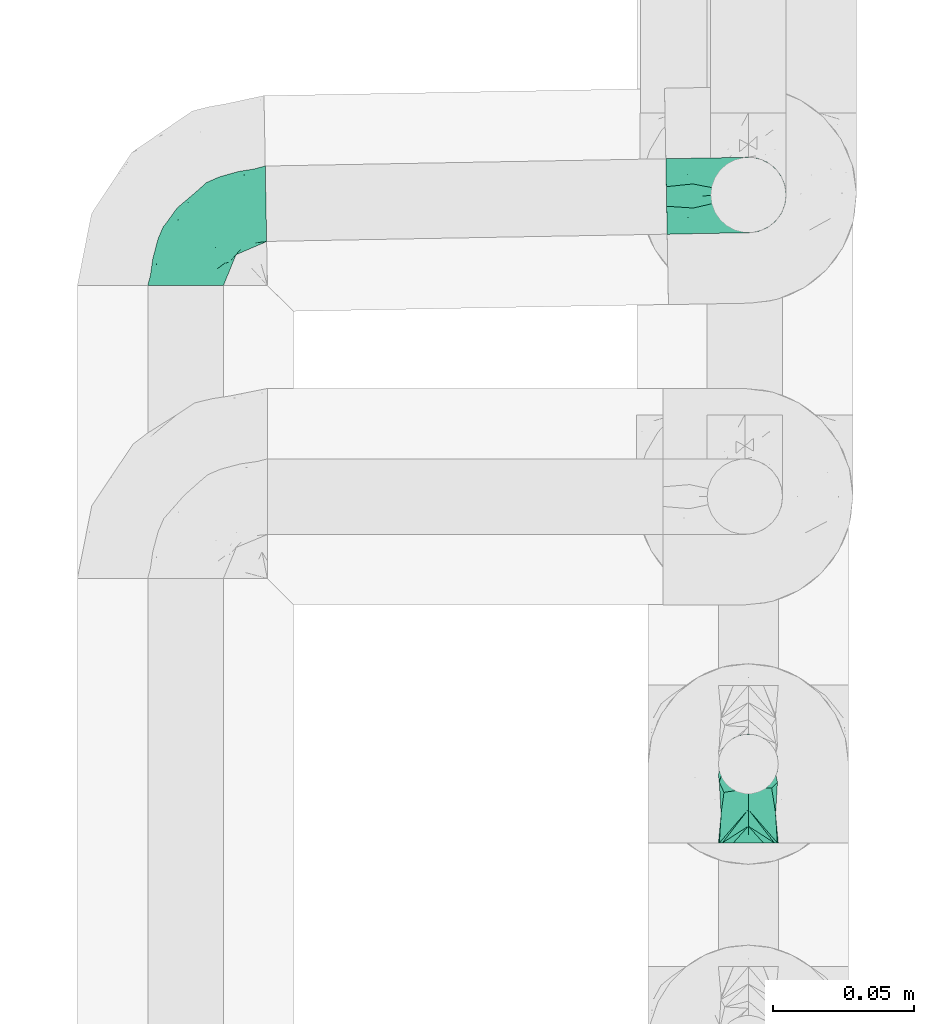
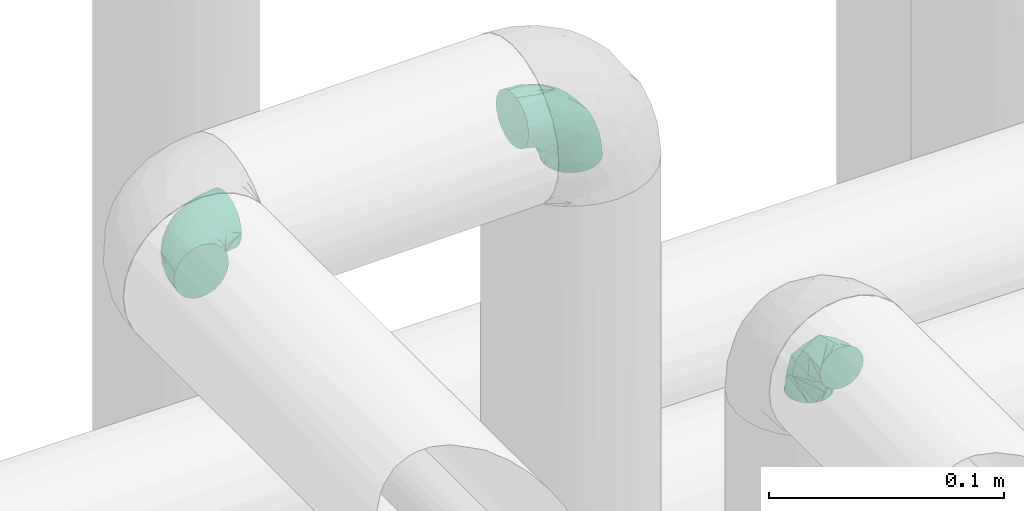
# One storey, part 813 of 827: 3 flow fittings.
"""IFC2X3 building model written with IfcOpenShell, lengths in millimetres."""

import ifcopenshell
import ifcopenshell.guid

model = None  # the IFC model being written
_history = None  # IfcOwnerHistory: only IFC2X3 demands one
_inside = {}  # id of a spatial element -> (the spatial element, [elements in it])
_under = {}  # id of a project, library or spatial element -> (it, [spatial elements below it])
_declared = {}  # id of a project -> (the project, [libraries it declares])
_typed = {}  # id of a type object -> (the type object, [elements of that type])
_made_of = {}  # id of a material, layer set ... -> (it, [elements and type objects made of it])


def new_model(schema):
    """Start an empty IFC model of exactly this schema.

    Asked for "IFC4X3", IfcOpenShell would pick the latest addendum, in which some entities
    have other attributes; the version numbers below select the first issue.
    IFC2X3 requires an IfcOwnerHistory on every rooted entity: one is made here for all.
    """
    global model, _history
    if schema == "IFC4X3":
        model = ifcopenshell.file(schema_version=(4, 3, 0, 0))
    else:
        model = ifcopenshell.file(schema=schema)
    _inside.clear()
    _under.clear()
    _declared.clear()
    _typed.clear()
    _made_of.clear()
    _history = None
    if model.schema == "IFC2X3":
        org = make("IfcOrganization", Name="unknown")
        user = make(
            "IfcPersonAndOrganization",
            ThePerson=make("IfcPerson", FamilyName="unknown"),
            TheOrganization=org,
        )
        app = make(
            "IfcApplication",
            ApplicationDeveloper=org,
            Version="unknown",
            ApplicationFullName="unknown",
            ApplicationIdentifier="unknown",
        )
        _history = make(
            "IfcOwnerHistory",
            OwningUser=user,
            OwningApplication=app,
            ChangeAction="ADDED",
            CreationDate=0,
        )
    return model


def make(cls, **values):
    """One entity of the class cls with the attributes given. An attribute that is None is left unset."""
    return model.create_entity(
        cls, **{name: value for name, value in values.items() if value is not None}
    )


def entity(cls, *values):
    """Any entity or typed value of the class cls, its attributes in the order of the schema. None: left unset."""
    e = model.create_entity(cls)
    for i, value in enumerate(values):
        if value is not None:
            e[i] = value
    return e


def rooted(cls, **values):
    """An entity with a GlobalId (a new one), such as an element, a storey or a relation."""
    return make(cls, GlobalId=ifcopenshell.guid.new(), OwnerHistory=_history, **values)


def si_unit(unit_type, name, prefix=None):
    """IfcSIUnit, for example si_unit("LENGTHUNIT", "METRE", prefix="MILLI")."""
    return make("IfcSIUnit", UnitType=unit_type, Prefix=prefix, Name=name)


def converted_unit(unit_type, name, factor, base, dimensions=None, offset=None):
    """IfcConversionBasedUnit, such as the inch: factor (a typed value) times the base unit."""
    return make(
        "IfcConversionBasedUnit"
        if offset is None
        else "IfcConversionBasedUnitWithOffset",
        ConversionOffset=offset,
        Dimensions=None
        if dimensions is None
        else entity("IfcDimensionalExponents", *dimensions),
        UnitType=unit_type,
        Name=name,
        ConversionFactor=make(
            "IfcMeasureWithUnit", ValueComponent=factor, UnitComponent=base
        ),
    )


def derived_unit(unit_type, elements):
    """IfcDerivedUnit: a product of units, each with its exponent."""
    return make(
        "IfcDerivedUnit",
        Elements=[
            make("IfcDerivedUnitElement", Unit=unit, Exponent=power)
            for unit, power in elements
        ],
        UnitType=unit_type,
    )


def assignment(units):
    """IfcUnitAssignment: the units of a project."""
    return None if units is None else make("IfcUnitAssignment", Units=units)


def point(xyz):
    """IfcCartesianPoint."""
    return None if xyz is None else make("IfcCartesianPoint", Coordinates=xyz)


def direction(xyz):
    """IfcDirection."""
    return None if xyz is None else make("IfcDirection", DirectionRatios=xyz)


def frame(location, z_axis=None, x_axis=None):
    """IfcAxis2Placement3D, a coordinate frame: its origin and axes. An axis left out is left unset."""
    return make(
        "IfcAxis2Placement3D",
        Location=point(location),
        Axis=direction(z_axis),
        RefDirection=direction(x_axis),
    )


def origin():
    """The frame at (0, 0, 0) with its axes left unset."""
    return frame((0.0, 0.0, 0.0))


def place(relative_to, where):
    """IfcLocalPlacement: puts the frame where relative to a parent placement (None: the world)."""
    return make(
        "IfcLocalPlacement", PlacementRelTo=relative_to, RelativePlacement=where
    )


def context(
    kind, dimensions, precision=None, world=None, true_north=None, identifier=None
):
    """IfcGeometricRepresentationContext, for example the 3D "Model" context."""
    return make(
        "IfcGeometricRepresentationContext",
        ContextIdentifier=identifier,
        ContextType=kind,
        CoordinateSpaceDimension=dimensions,
        Precision=precision,
        WorldCoordinateSystem=world,
        TrueNorth=true_north,
    )


def subcontext(parent, identifier, kind, view, scale=None):
    """IfcGeometricRepresentationSubContext, for example "Body" below "Model"."""
    return make(
        "IfcGeometricRepresentationSubContext",
        ContextIdentifier=identifier,
        ContextType=kind,
        ParentContext=parent,
        TargetScale=scale,
        TargetView=view,
    )


def project(units=None, contexts=None):
    """IfcProject with its units and contexts."""
    return rooted(
        "IfcProject",
        Name="project",
        RepresentationContexts=contexts,
        UnitsInContext=assignment(units),
    )


def spatial(cls, under=None, at=None, **own):
    """A site, building, storey or space (cls), placed at a placement, below another one or the project."""
    s = rooted(cls, ObjectPlacement=at, **own)
    if under is not None:
        _under.setdefault(under.id(), (under, []))[1].append(s)
    return s


def faces_of(points, faces, orient=None, outer=None):
    """IfcFace entities. A face is a list of loops; a loop is a list of indices into points, from 0.

    orient and outer hold one flag for each loop. By default every Orientation is true, the
    first loop of a face is its IfcFaceOuterBound and the others are IfcFaceBound.
    """
    made = []
    for i, loops in enumerate(faces):
        bounds = []
        for j, loop in enumerate(loops):
            is_outer = j == 0 if outer is None else outer[i][j]
            bounds.append(
                make(
                    "IfcFaceOuterBound" if is_outer else "IfcFaceBound",
                    Bound=make("IfcPolyLoop", Polygon=[points[k] for k in loop]),
                    Orientation=True if orient is None else orient[i][j],
                )
            )
        made.append(make("IfcFace", Bounds=bounds))
    return made


def faceted_brep(points, faces, orient=None, outer=None, voids=None):
    """IfcFacetedBrep: a solid bounded by flat faces; with voids (closed shells), ...WithVoids."""
    shared = [point(p) for p in points]
    hull = make("IfcClosedShell", CfsFaces=faces_of(shared, faces, orient, outer))
    if voids is None:
        return make("IfcFacetedBrep", Outer=hull)
    return make(
        "IfcFacetedBrepWithVoids",
        Outer=hull,
        Voids=[
            make(cls, CfsFaces=faces_of(shared, fs, o, b)) for cls, fs, o, b in voids
        ],
    )


def shape(context_of_items, identifier, shape_type, items):
    """IfcShapeRepresentation: the items that make up one representation, for example the "Body"."""
    return make(
        "IfcShapeRepresentation",
        ContextOfItems=context_of_items,
        RepresentationIdentifier=identifier,
        RepresentationType=shape_type,
        Items=items,
    )


def source(mapping_origin, context_of_items, identifier, shape_type, items):
    """IfcRepresentationMap: a shape defined once, which mapped items show again and again."""
    return make(
        "IfcRepresentationMap",
        MappingOrigin=mapping_origin,
        MappedRepresentation=shape(context_of_items, identifier, shape_type, items),
    )


def transform(
    local_origin,
    x_axis=None,
    y_axis=None,
    z_axis=None,
    scale=None,
    scale2=None,
    scale3=None,
    uniform=True,
):
    """IfcCartesianTransformationOperator3D, or its non-uniform kind. x_axis, y_axis, z_axis: its Axis1, 2, 3."""
    if uniform:
        return make(
            "IfcCartesianTransformationOperator3D",
            Axis1=direction(x_axis),
            Axis2=direction(y_axis),
            LocalOrigin=point(local_origin),
            Scale=scale,
            Axis3=direction(z_axis),
        )
    return make(
        "IfcCartesianTransformationOperator3DnonUniform",
        Axis1=direction(x_axis),
        Axis2=direction(y_axis),
        LocalOrigin=point(local_origin),
        Scale=scale,
        Axis3=direction(z_axis),
        Scale2=scale2,
        Scale3=scale3,
    )


def mapped(mapping_source, mapping_target):
    """IfcMappedItem: shows the shape of a source again, moved by a transform."""
    return make(
        "IfcMappedItem", MappingSource=mapping_source, MappingTarget=mapping_target
    )


def material(Name=None, Category=None):
    """IfcMaterial."""
    return make("IfcMaterial", Name=Name, Category=Category)


def made_of(thing, what):
    """Note that an element or type object is made of a material, layer set ...; save() writes the relation."""
    if what is not None:
        _made_of.setdefault(what.id(), (what, []))[1].append(thing)
    return thing


def type_object(cls, material=None, **own):
    """A type object (cls), such as IfcWallType, which elements share."""
    return made_of(rooted(cls, **own), material)


def type_shapes(of_type, sources):
    """Give a type object the sources (RepresentationMaps) that its elements show as mapped items."""
    of_type.RepresentationMaps = sources


def element(
    cls,
    number,
    at=None,
    inside=None,
    cuts=None,
    type_object=None,
    material=None,
    context=None,
    identifier="Body",
    shape_type=None,
    held_by="IfcProductDefinitionShape",
    body=None,
    shapes=None,
    **own,
):
    """One element of the class cls, such as IfcWall. Its Tag is "e" and its number.

    at: its placement. inside: the storey or other place that contains it. cuts: it is an
    opening in that element (IfcRelVoidsElement). A single representation is given by context,
    identifier, shape_type and body (its items); several are given by shapes. held_by: the class
    of the entity that holds the representations. save() writes the other relations.
    """
    e = rooted(cls, Tag="e%d" % number, ObjectPlacement=at, **own)
    if body is not None:
        shapes = [shape(context, identifier, shape_type, body)]
    if shapes is not None:
        e.Representation = make(held_by, Representations=shapes)
    if inside is not None:
        _inside.setdefault(inside.id(), (inside, []))[1].append(e)
    if cuts is not None:
        rooted(
            "IfcRelVoidsElement", RelatingBuildingElement=cuts, RelatedOpeningElement=e
        )
    if type_object is not None:
        _typed.setdefault(type_object.id(), (type_object, []))[1].append(e)
    return made_of(e, material)


def aggregate(whole, parts):
    """IfcRelAggregates: a whole, such as a stair, and the parts it consists of."""
    return rooted("IfcRelAggregates", RelatingObject=whole, RelatedObjects=parts)


def save(model, path):
    """Write the relations noted so far, then the file.

    IfcRelAggregates (storeys below a building ...), IfcRelContainedInSpatialStructure (elements
    in a storey), IfcRelDefinesByType, IfcRelAssociatesMaterial and IfcRelDeclares: one each for
    every whole, place, type object, material and project.
    """
    for whole, parts in _under.values():
        aggregate(whole, parts)
    for where, things in _inside.values():
        rooted(
            "IfcRelContainedInSpatialStructure",
            RelatedElements=things,
            RelatingStructure=where,
        )
    for kind, things in _typed.values():
        rooted("IfcRelDefinesByType", RelatedObjects=things, RelatingType=kind)
    for what, things in _made_of.values():
        rooted("IfcRelAssociatesMaterial", RelatedObjects=things, RelatingMaterial=what)
    for by, libraries in _declared.values():
        rooted("IfcRelDeclares", RelatingContext=by, RelatedDefinitions=libraries)
    model.write(path)


model = new_model("IFC2X3")

# Units and contexts
model_context = context("Model", 3, precision=0.01, world=origin(), true_north=direction((6.12303176911189e-17, 1.0)))
body_context = subcontext(model_context, "Body", "Model", "MODEL_VIEW")
ifc_project = project(units=[si_unit("LENGTHUNIT", "METRE", prefix="MILLI"), si_unit("AREAUNIT", "SQUARE_METRE"), si_unit("VOLUMEUNIT", "CUBIC_METRE"), converted_unit("PLANEANGLEUNIT", "DEGREE", entity("IfcRatioMeasure", 0.0174532925199433), si_unit("PLANEANGLEUNIT", "RADIAN"), dimensions=[0, 0, 0, 0, 0, 0, 0]), si_unit("MASSUNIT", "GRAM", prefix="KILO"), derived_unit("MASSDENSITYUNIT", [(si_unit("MASSUNIT", "GRAM", prefix="KILO"), 1), (si_unit("LENGTHUNIT", "METRE"), -3)]), derived_unit("MOMENTOFINERTIAUNIT", [(si_unit("LENGTHUNIT", "METRE"), 4)]), si_unit("TIMEUNIT", "SECOND"), si_unit("FREQUENCYUNIT", "HERTZ"), si_unit("THERMODYNAMICTEMPERATUREUNIT", "DEGREE_CELSIUS"), derived_unit("THERMALTRANSMITTANCEUNIT", [(si_unit("MASSUNIT", "GRAM", prefix="KILO"), 1), (si_unit("THERMODYNAMICTEMPERATUREUNIT", "KELVIN"), -1), (si_unit("TIMEUNIT", "SECOND"), -3)]), derived_unit("VOLUMETRICFLOWRATEUNIT", [(si_unit("LENGTHUNIT", "METRE"), 3), (si_unit("TIMEUNIT", "SECOND"), -1)]), derived_unit("MASSFLOWRATEUNIT", [(si_unit("MASSUNIT", "GRAM", prefix="KILO"), 1), (si_unit("TIMEUNIT", "SECOND"), -1)]), derived_unit("ROTATIONALFREQUENCYUNIT", [(si_unit("TIMEUNIT", "SECOND"), -1)]), si_unit("ELECTRICCURRENTUNIT", "AMPERE"), si_unit("ELECTRICVOLTAGEUNIT", "VOLT"), si_unit("POWERUNIT", "WATT"), si_unit("FORCEUNIT", "NEWTON", prefix="KILO"), si_unit("ILLUMINANCEUNIT", "LUX"), si_unit("LUMINOUSFLUXUNIT", "LUMEN"), si_unit("LUMINOUSINTENSITYUNIT", "CANDELA"), derived_unit("USERDEFINED", [(si_unit("MASSUNIT", "GRAM", prefix="KILO"), -1), (si_unit("LENGTHUNIT", "METRE"), -2), (si_unit("TIMEUNIT", "SECOND"), 3), (si_unit("LUMINOUSFLUXUNIT", "LUMEN"), 1)]), derived_unit("LINEARVELOCITYUNIT", [(si_unit("LENGTHUNIT", "METRE"), 1), (si_unit("TIMEUNIT", "SECOND"), -1)]), si_unit("PRESSUREUNIT", "PASCAL"), derived_unit("USERDEFINED", [(si_unit("LENGTHUNIT", "METRE"), -2), (si_unit("MASSUNIT", "GRAM", prefix="KILO"), 1), (si_unit("TIMEUNIT", "SECOND"), -2)]), derived_unit("LINEARFORCEUNIT", [(si_unit("MASSUNIT", "GRAM", prefix="KILO"), 1), (si_unit("LENGTHUNIT", "METRE"), 1), (si_unit("TIMEUNIT", "SECOND"), -2), (si_unit("LENGTHUNIT", "METRE"), -1)]), derived_unit("PLANARFORCEUNIT", [(si_unit("MASSUNIT", "GRAM", prefix="KILO"), 1), (si_unit("LENGTHUNIT", "METRE"), 1), (si_unit("TIMEUNIT", "SECOND"), -2), (si_unit("LENGTHUNIT", "METRE"), -2)])], contexts=[model_context])

# Site, building, storey
site_placement = place(None, origin())
site = spatial("IfcSite", under=ifc_project, at=site_placement, CompositionType="ELEMENT")
building_placement = place(site_placement, origin())
building = spatial("IfcBuilding", under=site, at=building_placement, CompositionType="ELEMENT")
storey_placement = place(building_placement, frame((0.0, 0.0, 28200.0)))
storey = spatial("IfcBuildingStorey", under=building, at=storey_placement, Name="08", CompositionType="ELEMENT", Elevation=28200.0)

# Flow fittings
ifc_material = material()
pipe_fitting_type_1 = type_object("IfcPipeFittingType", Name="ADSK_1", PredefinedType="NOTDEFINED", material=ifc_material)
shared_shape_1 = source(origin(), body_context, "Body", "Brep", [
    faceted_brep([(-28.0, 2.76, -10.29), (-28.0, 0.0, -10.65), (-28.0, -2.76, -10.29), (-28.0, -5.33, -9.22), (-28.0, -7.53, -7.53), (-28.0, -9.22, -5.33), (-28.0, -10.29, -2.76), (-28.0, -10.65, 0.0), (-28.0, -10.29, 2.76), (-28.0, -9.22, 5.32), (-28.0, -7.53, 7.53), (-28.0, -5.33, 9.22), (-28.0, -2.76, 10.29), (-28.0, 0.0, 10.65), (-28.0, 2.76, 10.29), (-28.0, 5.32, 9.22), (-28.0, 7.53, 7.53), (-28.0, 9.22, 5.32), (-28.0, 10.29, 2.76), (-28.0, 10.65, 0.0), (-28.0, 10.29, -2.76), (-28.0, 9.22, -5.33), (-28.0, 7.53, -7.53), (-28.0, 5.32, -9.22), (0.0, 28.0, -10.65), (-2.76, 28.0, -10.29), (-5.33, 28.0, -9.22), (-7.53, 28.0, -7.53), (-9.23, 28.0, -5.33), (-10.29, 28.0, -2.76), (-10.65, 28.0, 0.0), (-10.29, 28.0, 2.76), (-9.23, 28.0, 5.32), (-7.53, 28.0, 7.53), (-5.33, 28.0, 9.22), (-2.76, 28.0, 10.29), (0.0, 28.0, 10.65), (2.75, 28.0, 10.29), (5.32, 28.0, 9.22), (7.53, 28.0, 7.53), (9.22, 28.0, 5.32), (10.28, 28.0, 2.76), (10.65, 28.0, 0.0), (10.28, 28.0, -2.76), (9.22, 28.0, -5.33), (7.53, 28.0, -7.53), (5.32, 28.0, -9.22), (2.75, 28.0, -10.29), (-25.03, -9.85, 0.0), (-17.25, -2.67, 9.65), (-16.12, -7.47, 0.0), (-8.68, -5.47, 0.0), (2.67, 17.25, 9.65), (0.73, 8.55, 8.28), (5.47, 8.68, 0.0), (-1.6, 1.6, 0.0), (-6.42, 6.42, 10.35), (-22.06, -9.06, 0.0), (-5.14, -1.93, 0.0), (-13.19, 21.87, 0.0), (-12.06, 13.7, 8.37), (-7.31, 16.28, 9.78), (1.93, 5.14, 0.0), (-10.08, -1.14, 8.66), (-16.28, 7.31, 9.78), (-15.73, 15.73, 0.0), (-21.87, 13.19, 0.0), (7.46, 16.12, 0.0), (9.06, 22.06, 0.0), (9.85, 25.03, 0.0), (-18.33, -2.2, -9.98), (2.67, 17.25, -9.65), (-7.31, 16.28, -9.78), (-6.45, 6.38, -10.35), (-14.91, 4.23, -10.61), (-12.06, 13.68, -8.38), (1.13, 10.08, -8.66), (-9.15, -2.2, -7.46)], [[[0, 1, 2, 3, 4, 5, 6, 7, 8, 9, 10, 11, 12, 13, 14, 15, 16, 17, 18, 19, 20, 21, 22, 23]], [[24, 25, 26, 27, 28, 29, 30, 31, 32, 33, 34, 35, 36, 37, 38, 39, 40, 41, 42, 43, 44, 45, 46, 47]], [[8, 48, 9]], [[49, 50, 51]], [[52, 53, 54]], [[55, 53, 56]], [[11, 10, 57]], [[9, 57, 10]], [[56, 58, 55]], [[11, 50, 12]], [[12, 50, 49]], [[59, 60, 61]], [[53, 55, 62, 54]], [[63, 51, 58]], [[12, 49, 13]], [[14, 13, 49]], [[60, 64, 56]], [[63, 49, 51]], [[8, 7, 48]], [[49, 16, 15]], [[48, 57, 9]], [[19, 18, 64]], [[17, 16, 49]], [[17, 64, 18]], [[49, 15, 14]], [[33, 52, 34]], [[64, 65, 66, 19]], [[36, 52, 37]], [[67, 38, 37]], [[49, 64, 17]], [[35, 52, 36]], [[39, 38, 68]], [[56, 63, 58]], [[68, 38, 67]], [[41, 69, 42]], [[49, 63, 64]], [[53, 52, 61]], [[11, 57, 50]], [[30, 61, 31]], [[56, 61, 60]], [[61, 30, 59]], [[68, 40, 39]], [[32, 31, 61]], [[53, 61, 56]], [[52, 35, 34]], [[40, 69, 41]], [[52, 32, 61]], [[68, 69, 40]], [[33, 32, 52]], [[67, 37, 52]], [[52, 54, 67]], [[64, 60, 65]], [[63, 56, 64]], [[60, 59, 65]], [[23, 70, 0]], [[71, 72, 28]], [[73, 62, 55, 58]], [[22, 70, 23]], [[51, 50, 70]], [[57, 48, 5]], [[74, 70, 21]], [[5, 48, 6]], [[74, 21, 20]], [[75, 72, 73]], [[72, 71, 76]], [[70, 22, 21]], [[48, 7, 6]], [[3, 57, 4]], [[70, 2, 1]], [[66, 75, 74]], [[57, 3, 50]], [[3, 2, 50]], [[70, 1, 0]], [[59, 30, 72]], [[59, 75, 65]], [[58, 77, 73]], [[20, 19, 66]], [[74, 75, 73]], [[30, 29, 72]], [[76, 62, 73]], [[46, 68, 67]], [[75, 59, 72]], [[27, 71, 28]], [[57, 5, 4]], [[26, 25, 71]], [[69, 68, 44]], [[43, 42, 69]], [[26, 71, 27]], [[65, 75, 66]], [[24, 71, 25]], [[67, 71, 47]], [[28, 72, 29]], [[45, 68, 46]], [[67, 47, 46]], [[76, 71, 54]], [[24, 47, 71]], [[44, 43, 69]], [[54, 71, 67]], [[70, 77, 51]], [[73, 77, 74]], [[44, 68, 45]], [[70, 50, 2]], [[74, 77, 70]], [[76, 54, 62]], [[76, 73, 72]], [[20, 66, 74]], [[77, 58, 51]]]),
])
type_shapes(pipe_fitting_type_1, [shared_shape_1])
flow_fitting_1_placement = place(storey_placement, frame((17928.53, 10661.2, 2850.14), z_axis=(1.0, 0.0, 0.0), x_axis=(0.0, 0.0, 1.0)))
element("IfcFlowFitting", 1, at=flow_fitting_1_placement, inside=storey, type_object=pipe_fitting_type_1, material=ifc_material, Name="ADSK_1", ObjectType="ADSK_1", context=body_context, shape_type="MappedRepresentation", body=[
    mapped(shared_shape_1, transform((0.0, 0.0, 0.0), scale=1.0)),
])
pipe_fitting_type_2 = type_object("IfcPipeFittingType", Name="ADSK_1", PredefinedType="NOTDEFINED", material=ifc_material)
shared_shape_2 = source(origin(), body_context, "Body", "Brep", [
    faceted_brep([(-29.1, 0.0, -13.45), (-29.1, -3.48, -12.99), (-29.1, -6.73, -11.65), (-29.1, -9.51, -9.51), (-29.1, -11.65, -6.73), (-29.1, -12.99, -3.48), (-29.1, -13.45, 0.0), (-29.1, -12.99, 3.48), (-29.1, -11.65, 6.72), (-29.1, -9.51, 9.51), (-29.1, -6.73, 11.65), (-29.1, -3.48, 12.99), (-29.1, 0.0, 13.45), (-29.1, 3.48, 12.99), (-29.1, 6.72, 11.65), (-29.1, 9.51, 9.51), (-29.1, 11.65, 6.72), (-29.1, 12.99, 3.48), (-29.1, 13.45, 0.0), (-29.1, 12.99, -3.48), (-29.1, 11.65, -6.73), (-29.1, 9.51, -9.51), (-29.1, 6.72, -11.65), (-29.1, 3.48, -12.99), (-3.48, 29.1, -12.99), (-6.72, 29.1, -11.65), (-9.51, 29.1, -9.51), (-11.64, 29.1, -6.73), (-12.99, 29.1, -3.48), (-13.45, 29.1, 0.0), (-12.99, 29.1, 3.48), (-11.64, 29.1, 6.72), (-9.51, 29.1, 9.51), (-6.72, 29.1, 11.65), (-3.48, 29.1, 12.99), (0.0, 29.1, 13.45), (3.48, 29.1, 12.99), (6.73, 29.1, 11.65), (9.51, 29.09, 9.51), (11.65, 29.09, 6.72), (13.0, 29.09, 3.48), (13.45, 29.09, 0.0), (13.0, 29.09, -3.48), (11.65, 29.09, -6.73), (9.51, 29.09, -9.51), (6.73, 29.1, -11.65), (3.48, 29.1, -12.99), (0.0, 29.1, -13.45), (-19.61, -11.66, 4.28), (-21.41, -10.36, 7.6), (-16.25, -10.01, 0.0), (-12.48, -9.76, 2.75), (-15.97, 6.12, 13.19), (-20.48, 2.21, 13.42), (-14.48, 3.64, 13.45), (-0.04, 0.04, 0.0), (0.49, -0.45, 4.38), (-3.67, -4.15, 4.26), (-22.67, -11.73, 0.0), (-21.45, -4.97, 12.13), (-11.59, -2.85, 11.28), (-14.76, 0.17, 13.07), (-19.08, -7.58, 10.06), (-22.36, -1.69, 13.23), (-7.82, -7.75, 0.0), (-5.53, -2.55, 8.58), (-1.33, -0.87, 6.53), (-1.15, 1.15, 8.49), (-22.45, 5.38, 12.69), (-14.03, 21.05, 6.04), (-3.19, 3.19, 11.14), (-5.07, 25.04, 12.59), (-1.96, 21.79, 13.41), (-22.68, 11.31, 8.78), (-18.16, 12.64, 9.68), (-20.45, 14.33, 6.11), (-4.12, 10.1, 13.26), (-7.65, 3.08, 12.63), (-2.02, 8.24, 12.45), (-24.91, 8.22, 10.95), (-5.07, 14.27, 13.42), (-10.71, 10.71, 13.09), (-8.96, 6.48, 13.4), (-19.69, 16.14, 3.1), (-18.03, 18.03, 0.0), (-23.04, 15.96, 0.0), (-25.26, 12.69, 5.56), (4.97, 21.45, 12.13), (7.58, 19.08, 10.06), (1.69, 22.36, 13.23), (10.36, 21.4, 7.6), (8.11, 12.68, 6.86), (11.66, 19.61, 4.28), (-6.03, 19.64, 12.79), (9.76, 12.48, 2.75), (10.01, 16.25, 0.0), (-14.58, 16.06, 9.44), (-11.19, 23.14, 8.74), (-16.28, 16.8, 7.24), (-11.99, -5.68, 9.36), (-15.42, 20.78, 3.08), (5.79, 12.02, 9.27), (2.85, 11.59, 11.28), (2.55, 5.53, 8.58), (-15.74, 23.57, 0.0), (-15.95, 23.04, 0.0), (-24.61, 13.88, 2.39), (-8.61, 22.49, 11.12), (-15.27, 9.55, 12.42), (-10.66, 15.59, 11.91), (-14.97, 12.8, 11.14), (11.73, 22.67, 0.0), (-12.68, -8.11, 6.86), (7.75, 7.82, 0.0), (-19.6, 9.46, 11.31), (-8.3, 15.02, 12.85), (-0.17, 14.76, 13.07), (-6.89, -5.2, 6.52), (7.5, 8.93, 4.47), (5.22, 6.95, 6.56), (-8.84, -7.47, 4.42), (3.86, 3.93, 0.0), (4.18, 3.74, 4.31), (-23.56, 15.74, 0.0), (-3.93, -3.86, 0.0), (-21.79, 1.97, -13.41), (-11.31, 22.68, -8.78), (-14.32, 20.45, -6.11), (-12.69, 25.26, -5.56), (4.97, 21.45, -12.13), (2.85, 11.59, -11.28), (-0.17, 14.76, -13.07), (-25.04, 5.08, -12.59), (-16.79, 16.29, -7.24), (-20.78, 15.42, -3.08), (-16.14, 19.7, -3.1), (-12.02, -5.79, -9.27), (-11.59, -2.85, -11.28), (-5.53, -2.55, -8.58), (-23.14, 11.19, -8.74), (-22.48, 8.61, -11.12), (-1.33, -0.87, -6.53), (-3.67, -4.15, -4.26), (-6.89, -5.2, -6.52), (-19.64, 6.03, -12.79), (-15.59, 10.66, -11.91), (-14.27, 5.08, -13.42), (-10.71, 10.71, -13.09), (-6.48, 8.96, -13.4), (-19.61, -11.66, -4.28), (-21.41, -10.36, -7.6), (-12.48, -9.76, -2.75), (11.66, 19.61, -4.28), (-12.68, -8.11, -6.86), (-22.36, -1.69, -13.23), (-16.06, 14.58, -9.44), (5.68, 11.99, -9.36), (7.58, 19.08, -10.06), (-19.08, -7.58, -10.06), (-21.45, -4.97, -12.13), (-9.55, 15.27, -12.42), (-12.8, 14.98, -11.14), (-8.22, 24.91, -10.95), (10.36, 21.4, -7.6), (-5.38, 22.45, -12.69), (1.69, 22.36, -13.23), (-2.21, 20.48, -13.42), (-12.63, 18.16, -9.68), (-21.04, 14.04, -6.04), (9.76, 12.48, -2.75), (-10.1, 4.13, -13.26), (-3.08, 7.66, -12.63), (-8.24, 2.02, -12.45), (-13.88, 24.62, -2.39), (8.11, 12.68, -6.86), (-6.12, 15.97, -13.19), (-3.63, 14.48, -13.45), (-9.46, 19.6, -11.31), (-15.02, 8.3, -12.85), (-14.76, 0.17, -13.07), (-3.19, 3.19, -11.14), (5.22, 6.95, -6.56), (2.55, 5.53, -8.58), (0.49, -0.45, -4.38), (4.18, 3.74, -4.31), (-8.84, -7.47, -4.42), (-1.15, 1.15, -8.49), (7.5, 8.93, -4.47)], [[[0, 1, 2, 3, 4, 5, 6, 7, 8, 9, 10, 11, 12, 13, 14, 15, 16, 17, 18, 19, 20, 21, 22, 23]], [[24, 25, 26, 27, 28, 29, 30, 31, 32, 33, 34, 35, 36, 37, 38, 39, 40, 41, 42, 43, 44, 45, 46, 47]], [[48, 49, 8]], [[48, 50, 51]], [[52, 53, 54]], [[55, 56, 57]], [[49, 9, 8]], [[58, 48, 7]], [[59, 60, 61]], [[62, 10, 9]], [[62, 59, 10]], [[12, 63, 53]], [[51, 50, 64]], [[65, 66, 67]], [[12, 11, 63]], [[68, 14, 13]], [[31, 30, 69]], [[65, 70, 60]], [[34, 71, 72]], [[73, 74, 75]], [[76, 77, 78]], [[14, 79, 15]], [[16, 15, 73]], [[80, 81, 82]], [[83, 84, 85]], [[73, 75, 86]], [[37, 87, 88]], [[88, 38, 37]], [[36, 35, 89]], [[90, 91, 92]], [[93, 80, 72]], [[35, 34, 72]], [[10, 59, 11]], [[92, 94, 95]], [[96, 97, 98]], [[90, 92, 39]], [[99, 60, 62]], [[40, 39, 92]], [[87, 37, 36]], [[100, 84, 83]], [[50, 48, 58]], [[100, 83, 98]], [[101, 102, 103]], [[104, 105, 84, 100, 29]], [[48, 8, 7]], [[86, 17, 16]], [[106, 18, 17]], [[32, 97, 107]], [[108, 109, 110]], [[109, 93, 107]], [[97, 96, 107]], [[71, 107, 93]], [[71, 34, 33]], [[92, 111, 40]], [[33, 32, 107]], [[68, 13, 53]], [[88, 87, 102]], [[12, 53, 13]], [[49, 112, 62]], [[39, 38, 90]], [[95, 94, 113]], [[52, 54, 82]], [[108, 68, 52]], [[79, 73, 15]], [[114, 110, 74]], [[32, 31, 97]], [[115, 109, 81]], [[93, 115, 80]], [[89, 72, 116]], [[106, 75, 83]], [[106, 83, 85]], [[83, 75, 98]], [[100, 30, 29]], [[60, 59, 62]], [[63, 59, 61]], [[112, 117, 99]], [[60, 70, 77]], [[89, 87, 36]], [[116, 78, 102]], [[116, 102, 87]], [[102, 70, 103]], [[112, 49, 48]], [[62, 9, 49]], [[38, 88, 90]], [[91, 90, 88]], [[52, 68, 53]], [[79, 68, 114]], [[113, 94, 118]], [[119, 101, 103]], [[117, 65, 99]], [[117, 120, 57]], [[119, 91, 101]], [[65, 67, 70]], [[65, 117, 66]], [[121, 113, 122, 55]], [[56, 55, 122]], [[31, 69, 97]], [[97, 69, 98]], [[107, 96, 109]], [[108, 110, 114]], [[52, 82, 81]], [[116, 72, 80]], [[77, 82, 61]], [[80, 82, 76]], [[72, 89, 35]], [[87, 89, 116]], [[59, 63, 11]], [[53, 63, 61]], [[7, 6, 58]], [[111, 92, 95]], [[111, 41, 40]], [[108, 52, 81]], [[109, 108, 81]], [[68, 108, 114]], [[109, 96, 110]], [[74, 110, 96]], [[74, 96, 98]], [[114, 74, 73]], [[53, 61, 54]], [[61, 82, 54]], [[91, 88, 101]], [[112, 48, 51]], [[92, 91, 94]], [[91, 119, 118]], [[106, 85, 123, 18]], [[106, 17, 86]], [[60, 77, 61]], [[78, 77, 70]], [[102, 78, 70]], [[76, 78, 116]], [[80, 76, 116]], [[77, 76, 82]], [[68, 79, 14]], [[73, 79, 114]], [[73, 86, 16]], [[106, 86, 75]], [[107, 71, 33]], [[72, 71, 93]], [[98, 69, 100]], [[74, 98, 75]], [[30, 100, 69]], [[112, 99, 62]], [[65, 60, 99]], [[120, 112, 51]], [[66, 117, 57]], [[57, 56, 66]], [[66, 122, 119]], [[112, 120, 117]], [[64, 120, 51]], [[57, 64, 124, 55]], [[122, 66, 56]], [[66, 103, 67]], [[70, 67, 103]], [[64, 57, 120]], [[102, 101, 88]], [[66, 119, 103]], [[118, 119, 122]], [[118, 122, 113]], [[91, 118, 94]], [[80, 115, 81]], [[93, 109, 115]], [[23, 125, 0]], [[126, 127, 128]], [[129, 130, 131]], [[23, 22, 132]], [[133, 134, 135]], [[136, 137, 138]], [[21, 139, 140]], [[141, 142, 143]], [[144, 140, 145]], [[143, 136, 138]], [[146, 147, 148]], [[144, 132, 140]], [[5, 4, 149]], [[4, 3, 150]], [[45, 129, 46]], [[151, 50, 149]], [[152, 43, 42]], [[42, 41, 111]], [[150, 149, 4]], [[153, 149, 150]], [[154, 1, 0]], [[139, 155, 140]], [[156, 130, 157]], [[149, 58, 5]], [[18, 123, 85, 84, 134]], [[158, 159, 137]], [[84, 105, 135]], [[160, 145, 161]], [[143, 153, 136]], [[27, 26, 126]], [[25, 162, 26]], [[152, 163, 43]], [[25, 24, 164]], [[47, 165, 166]], [[158, 3, 2]], [[167, 127, 126]], [[20, 19, 168]], [[47, 46, 165]], [[44, 157, 45]], [[23, 132, 125]], [[44, 43, 163]], [[158, 2, 159]], [[47, 166, 24]], [[129, 45, 157]], [[164, 24, 166]], [[134, 84, 135]], [[95, 169, 152]], [[22, 21, 140]], [[144, 146, 125]], [[111, 152, 42]], [[95, 152, 111]], [[170, 171, 172]], [[155, 139, 133]], [[28, 27, 128]], [[159, 2, 1]], [[173, 29, 28]], [[50, 151, 64]], [[169, 95, 113]], [[163, 174, 157]], [[175, 176, 148]], [[160, 164, 175]], [[162, 126, 26]], [[177, 161, 167]], [[21, 20, 139]], [[144, 145, 178]], [[144, 178, 146]], [[154, 125, 179]], [[173, 127, 135]], [[173, 135, 105]], [[135, 127, 133]], [[134, 19, 18]], [[154, 159, 1]], [[179, 172, 137]], [[179, 137, 159]], [[137, 180, 138]], [[130, 129, 157]], [[165, 129, 131]], [[174, 181, 156]], [[130, 180, 171]], [[3, 158, 150]], [[153, 150, 158]], [[174, 163, 152]], [[157, 44, 163]], [[175, 164, 166]], [[162, 164, 177]], [[130, 182, 180]], [[181, 141, 182]], [[55, 183, 184]], [[64, 151, 185]], [[183, 55, 142]], [[156, 181, 182]], [[180, 182, 186]], [[181, 187, 184]], [[64, 142, 55, 124]], [[20, 168, 139]], [[139, 168, 133]], [[140, 155, 145]], [[160, 161, 177]], [[175, 148, 147]], [[179, 125, 146]], [[171, 148, 131]], [[146, 148, 170]], [[125, 154, 0]], [[159, 154, 179]], [[129, 165, 46]], [[166, 165, 131]], [[58, 149, 50]], [[58, 6, 5]], [[175, 166, 176]], [[160, 175, 147]], [[145, 160, 147]], [[164, 160, 177]], [[145, 155, 161]], [[167, 161, 155]], [[167, 155, 133]], [[177, 167, 126]], [[166, 131, 176]], [[131, 148, 176]], [[149, 153, 151]], [[153, 143, 185]], [[145, 147, 178]], [[174, 152, 169]], [[173, 105, 104, 29]], [[173, 28, 128]], [[130, 171, 131]], [[172, 171, 180]], [[137, 172, 180]], [[170, 172, 179]], [[146, 170, 179]], [[171, 170, 148]], [[164, 162, 25]], [[126, 162, 177]], [[126, 128, 27]], [[173, 128, 127]], [[140, 132, 22]], [[125, 132, 144]], [[133, 168, 134]], [[167, 133, 127]], [[19, 134, 168]], [[153, 158, 136]], [[137, 136, 158]], [[141, 143, 138]], [[185, 143, 142]], [[186, 141, 138]], [[183, 142, 141]], [[185, 142, 64]], [[153, 185, 151]], [[180, 186, 138]], [[182, 141, 186]], [[141, 184, 183]], [[184, 113, 121, 55]], [[174, 156, 157]], [[182, 130, 156]], [[187, 174, 169]], [[141, 181, 184]], [[174, 187, 181]], [[113, 187, 169]], [[113, 184, 187]], [[146, 178, 147]]]),
])
type_shapes(pipe_fitting_type_2, [shared_shape_2])
flow_fitting_2_placement = place(storey_placement, frame((17928.52, 10863.43, 2850.1), z_axis=(0.0181743893418236, -0.999834832145816, 0.0), x_axis=(0.0, 0.0, 1.0)))
element("IfcFlowFitting", 2, at=flow_fitting_2_placement, inside=storey, type_object=pipe_fitting_type_2, material=ifc_material, Name="ADSK_1", ObjectType="ADSK_1", context=body_context, shape_type="MappedRepresentation", body=[
    mapped(shared_shape_2, transform((0.0, 0.0, 0.0), scale=1.0)),
])
pipe_fitting_type_3 = type_object("IfcPipeFittingType", Name="ADSK_1", PredefinedType="NOTDEFINED", material=ifc_material)
shared_shape_3 = source(origin(), body_context, "Body", "Brep", [
    faceted_brep([(-28.58, 0.0, -13.45), (-28.58, -3.48, -12.99), (-28.58, -6.73, -11.65), (-28.58, -9.51, -9.51), (-28.58, -11.65, -6.73), (-28.58, -12.99, -3.48), (-28.58, -13.45, 0.0), (-28.58, -12.99, 3.48), (-28.58, -11.65, 6.72), (-28.58, -9.51, 9.51), (-28.58, -6.73, 11.65), (-28.58, -3.48, 12.99), (-28.58, 0.0, 13.45), (-28.58, 3.48, 12.99), (-28.58, 6.72, 11.65), (-28.58, 9.51, 9.51), (-28.58, 11.65, 6.72), (-28.58, 12.99, 3.48), (-28.58, 13.45, 0.0), (-28.58, 12.99, -3.48), (-28.58, 11.65, -6.73), (-28.58, 9.51, -9.51), (-28.58, 6.72, -11.65), (-28.58, 3.48, -12.99), (4.0, 28.51, -12.99), (0.52, 28.57, -13.45), (-2.96, 28.63, -12.99), (-6.2, 28.69, -11.65), (-8.99, 28.74, -9.51), (-11.13, 28.78, -6.73), (-12.47, 28.81, -3.48), (-12.93, 28.82, 0.0), (-12.47, 28.81, 3.48), (-11.13, 28.78, 6.72), (-8.99, 28.74, 9.51), (-6.2, 28.69, 11.65), (-2.96, 28.63, 12.99), (0.52, 28.57, 13.45), (4.0, 28.51, 12.99), (7.24, 28.45, 11.65), (10.03, 28.4, 9.51), (12.17, 28.36, 6.72), (13.51, 28.34, 3.48), (13.97, 28.33, 0.0), (13.51, 28.34, -3.48), (12.17, 28.36, -6.73), (10.03, 28.4, -9.51), (7.24, 28.45, -11.65), (-19.08, -11.65, 4.29), (-20.89, -10.35, 7.6), (-15.72, -10.05, 0.0), (-12.06, -9.81, 2.74), (-15.57, 6.06, 13.19), (-20.03, 2.2, 13.42), (-14.14, 3.61, 13.45), (-3.12, -4.09, 4.34), (-6.57, -7.02, 2.62), (-3.64, -4.06, 0.0), (-22.15, -11.75, 0.0), (-20.93, -4.97, 12.13), (-11.23, -2.92, 11.29), (-14.4, 0.13, 13.08), (-18.56, -7.57, 10.07), (-0.85, -0.82, 6.65), (2.72, 5.14, 8.63), (-1.51, 1.54, 9.49), (-7.52, -7.88, 0.0), (6.07, 11.51, 9.26), (3.12, 11.18, 11.29), (-21.93, -1.69, 13.23), (-21.95, 5.39, 12.68), (-13.65, 20.8, 6.02), (-5.19, -2.63, 8.63), (-2.94, 2.99, 11.17), (-4.63, 24.68, 12.58), (-1.58, 21.34, 13.41), (-22.19, 11.31, 8.77), (-17.77, 12.49, 9.73), (-20.03, 14.28, 6.08), (-3.85, 9.75, 13.25), (-7.29, 3.05, 12.66), (-1.66, 8.03, 12.45), (-24.48, 8.21, 10.95), (-8.71, 6.35, 13.41), (-4.81, 14.03, 13.42), (-19.24, 16.09, 3.09), (-17.61, 17.93, 0.0), (-22.51, 15.93, 0.0), (-24.8, 12.68, 5.55), (5.35, 20.84, 12.13), (7.91, 18.42, 10.07), (2.09, 21.89, 13.23), (10.73, 20.7, 7.6), (8.32, 12.02, 6.88), (12.0, 18.86, 4.29), (-24.14, 13.87, 2.36), (10.03, 11.88, 2.74), (10.33, 15.53, 0.0), (-14.27, 15.86, 9.42), (-10.78, 22.83, 8.73), (-15.9, 16.65, 7.24), (-11.58, -5.69, 9.4), (-14.99, 20.63, 3.1), (-15.52, 22.79, 0.0), (-5.66, 19.35, 12.78), (-8.21, 22.15, 11.11), (-14.96, 9.43, 12.41), (-10.26, 15.41, 11.92), (-14.58, 12.69, 11.15), (12.15, 21.93, 0.0), (-12.17, -8.1, 6.88), (8.01, 7.38, 0.0), (-7.94, 14.81, 12.84), (-10.39, 10.58, 13.08), (0.13, 14.4, 13.08), (-19.23, 9.41, 11.29), (-6.41, -5.2, 6.57), (4.32, 3.42, 4.62), (7.08, 6.37, 2.65), (4.13, 3.57, 0.0), (3.05, 0.94, 2.31), (0.24, -0.25, 0.0), (-21.31, 1.97, -13.41), (-10.9, 22.39, -8.77), (-13.92, 20.29, -6.08), (-12.23, 25.02, -5.55), (5.35, 20.84, -12.13), (3.12, 11.18, -11.29), (0.13, 14.4, -13.08), (-24.59, 5.08, -12.58), (-14.03, 22.38, -3.15), (-11.62, -5.86, -9.26), (-11.23, -2.92, -11.29), (-5.19, -2.63, -8.63), (-22.63, 11.19, -8.73), (-22.0, 8.61, -11.11), (-3.12, -4.09, -4.34), (-6.41, -5.2, -6.57), (-0.85, -0.82, -6.65), (-19.25, 6.01, -12.78), (-15.22, 10.54, -11.92), (-6.19, 8.83, -13.41), (-9.68, 4.03, -13.25), (-13.94, 5.06, -13.42), (-19.08, -11.65, -4.29), (-20.89, -10.35, -7.6), (-12.06, -9.81, -2.74), (12.0, 18.86, -4.29), (-12.17, -8.1, -6.88), (-21.93, -1.69, -13.23), (5.9, 11.47, -9.4), (7.91, 18.42, -10.07), (-24.13, 13.88, -2.37), (-18.56, -7.57, -10.07), (-20.93, -4.97, -12.13), (-9.15, 15.13, -12.41), (-12.42, 14.81, -11.15), (-7.77, 24.62, -10.95), (10.73, 20.7, -7.6), (-4.99, 22.05, -12.68), (2.09, 21.89, -13.23), (-1.84, 20.06, -13.42), (-12.17, 18.0, -9.73), (-20.55, 14.03, -6.02), (-19.24, 16.09, -3.11), (10.03, 11.88, -2.74), (-15.59, 14.55, -9.42), (-2.91, 7.35, -12.66), (-7.99, 1.81, -12.45), (-16.36, 16.2, -7.24), (8.32, 12.02, -6.88), (-5.78, 15.68, -13.19), (-3.35, 14.2, -13.45), (-14.66, 8.21, -12.84), (-10.39, 10.58, -13.08), (-14.4, 0.13, -13.08), (-9.06, 19.4, -11.29), (-2.94, 2.99, -11.17), (2.72, 5.14, -8.63), (4.32, 3.42, -4.62), (3.05, 0.94, -2.31), (-6.57, -7.02, -2.62), (-1.51, 1.54, -9.49), (7.08, 6.37, -2.65)], [[[0, 1, 2, 3, 4, 5, 6, 7, 8, 9, 10, 11, 12, 13, 14, 15, 16, 17, 18, 19, 20, 21, 22, 23]], [[24, 25, 26, 27, 28, 29, 30, 31, 32, 33, 34, 35, 36, 37, 38, 39, 40, 41, 42, 43, 44, 45, 46, 47]], [[48, 49, 8]], [[48, 50, 51]], [[52, 53, 54]], [[55, 56, 57]], [[49, 9, 8]], [[58, 48, 7]], [[59, 60, 61]], [[62, 10, 9]], [[62, 59, 10]], [[63, 64, 65]], [[51, 50, 66]], [[67, 68, 64]], [[12, 11, 69]], [[70, 14, 13]], [[33, 32, 71]], [[72, 73, 60]], [[36, 74, 75]], [[76, 77, 78]], [[79, 80, 81]], [[14, 82, 15]], [[16, 15, 76]], [[83, 79, 84]], [[85, 86, 87]], [[76, 78, 88]], [[39, 89, 90]], [[90, 40, 39]], [[38, 37, 91]], [[92, 93, 94]], [[95, 18, 17]], [[37, 36, 75]], [[10, 59, 11]], [[94, 96, 97]], [[98, 99, 100]], [[92, 94, 41]], [[101, 60, 62]], [[42, 41, 94]], [[89, 39, 38]], [[86, 102, 31, 103]], [[50, 48, 58]], [[32, 31, 102]], [[12, 69, 53]], [[86, 85, 102]], [[48, 8, 7]], [[88, 17, 16]], [[104, 84, 75]], [[34, 99, 105]], [[106, 107, 108]], [[107, 104, 105]], [[35, 34, 105]], [[74, 105, 104]], [[74, 36, 35]], [[94, 109, 42]], [[99, 98, 105]], [[70, 13, 53]], [[90, 89, 68]], [[12, 53, 13]], [[49, 110, 62]], [[41, 40, 92]], [[97, 96, 111]], [[52, 54, 83]], [[106, 70, 52]], [[34, 33, 99]], [[112, 107, 113]], [[104, 112, 84]], [[91, 75, 114]], [[82, 76, 15]], [[115, 108, 77]], [[95, 78, 85]], [[95, 85, 87]], [[85, 78, 100]], [[60, 59, 62]], [[69, 59, 61]], [[110, 116, 101]], [[60, 73, 80]], [[91, 89, 38]], [[114, 81, 68]], [[114, 68, 89]], [[68, 73, 64]], [[110, 49, 48]], [[62, 9, 49]], [[40, 90, 92]], [[93, 92, 90]], [[52, 70, 53]], [[82, 70, 115]], [[64, 117, 93]], [[64, 93, 67]], [[116, 72, 101]], [[110, 51, 56]], [[118, 119, 111]], [[73, 72, 65]], [[72, 116, 63]], [[120, 118, 117]], [[96, 118, 111]], [[33, 71, 99]], [[99, 71, 100]], [[105, 98, 107]], [[106, 108, 115]], [[83, 84, 113]], [[114, 75, 84]], [[83, 113, 52]], [[83, 61, 80]], [[75, 91, 37]], [[89, 91, 114]], [[59, 69, 11]], [[53, 69, 61]], [[7, 6, 58]], [[109, 94, 97]], [[109, 43, 42]], [[106, 52, 113]], [[107, 106, 113]], [[70, 106, 115]], [[107, 98, 108]], [[77, 108, 98]], [[77, 98, 100]], [[115, 77, 76]], [[56, 51, 66]], [[110, 48, 51]], [[94, 93, 96]], [[118, 93, 117]], [[53, 61, 54]], [[61, 83, 54]], [[18, 95, 87]], [[95, 17, 88]], [[60, 80, 61]], [[81, 80, 73]], [[68, 81, 73]], [[79, 81, 114]], [[84, 79, 114]], [[80, 79, 83]], [[93, 118, 96]], [[120, 121, 119]], [[70, 82, 14]], [[118, 120, 119]], [[55, 120, 117]], [[57, 121, 55]], [[56, 55, 116]], [[56, 66, 57]], [[121, 120, 55]], [[76, 82, 115]], [[105, 74, 35]], [[75, 74, 104]], [[76, 88, 16]], [[95, 88, 78]], [[85, 100, 71]], [[77, 100, 78]], [[85, 71, 102]], [[32, 102, 71]], [[110, 101, 62]], [[72, 60, 101]], [[56, 116, 110]], [[63, 116, 55]], [[55, 117, 63]], [[64, 63, 117]], [[93, 90, 67]], [[68, 67, 90]], [[63, 65, 72]], [[64, 73, 65]], [[84, 112, 113]], [[104, 107, 112]], [[23, 122, 0]], [[123, 124, 125]], [[126, 127, 128]], [[23, 22, 129]], [[30, 125, 130]], [[131, 132, 133]], [[21, 134, 135]], [[136, 137, 138]], [[139, 135, 140]], [[137, 131, 133]], [[141, 142, 143]], [[139, 129, 135]], [[5, 4, 144]], [[4, 3, 145]], [[47, 126, 24]], [[146, 50, 144]], [[147, 45, 44]], [[44, 43, 109]], [[145, 144, 4]], [[148, 144, 145]], [[149, 1, 0]], [[22, 21, 135]], [[150, 127, 151]], [[144, 58, 5]], [[18, 87, 152]], [[153, 154, 132]], [[149, 154, 1]], [[155, 140, 156]], [[137, 148, 131]], [[29, 28, 123]], [[27, 157, 28]], [[147, 158, 45]], [[27, 26, 159]], [[25, 160, 161]], [[153, 3, 2]], [[162, 124, 123]], [[20, 19, 163]], [[25, 24, 160]], [[46, 151, 47]], [[23, 129, 122]], [[46, 45, 158]], [[153, 2, 154]], [[25, 161, 26]], [[126, 47, 151]], [[159, 26, 161]], [[86, 164, 87]], [[97, 165, 147]], [[134, 166, 135]], [[86, 103, 31, 130]], [[109, 147, 44]], [[97, 147, 109]], [[142, 167, 168]], [[166, 134, 169]], [[30, 29, 125]], [[154, 2, 1]], [[139, 143, 122]], [[50, 146, 66]], [[165, 97, 111]], [[158, 170, 151]], [[171, 172, 141]], [[155, 159, 171]], [[21, 20, 134]], [[173, 140, 174]], [[139, 173, 143]], [[149, 122, 175]], [[157, 123, 28]], [[176, 156, 162]], [[163, 19, 152]], [[87, 164, 152]], [[169, 164, 124]], [[130, 31, 30]], [[130, 164, 86]], [[175, 168, 132]], [[175, 132, 154]], [[132, 177, 133]], [[127, 126, 151]], [[160, 126, 128]], [[150, 170, 178]], [[127, 177, 167]], [[3, 153, 145]], [[148, 145, 153]], [[170, 158, 147]], [[151, 46, 158]], [[171, 159, 161]], [[157, 159, 176]], [[127, 178, 177]], [[178, 179, 138]], [[136, 179, 180]], [[181, 66, 146]], [[136, 57, 181]], [[178, 170, 179]], [[182, 177, 178]], [[183, 170, 165]], [[180, 183, 119]], [[20, 163, 134]], [[134, 163, 169]], [[135, 166, 140]], [[155, 156, 176]], [[141, 143, 174]], [[175, 122, 143]], [[141, 174, 171]], [[141, 128, 167]], [[122, 149, 0]], [[154, 149, 175]], [[126, 160, 24]], [[161, 160, 128]], [[58, 144, 50]], [[58, 6, 5]], [[171, 161, 172]], [[155, 171, 174]], [[140, 155, 174]], [[159, 155, 176]], [[140, 166, 156]], [[162, 156, 166]], [[162, 166, 169]], [[176, 162, 123]], [[144, 148, 146]], [[148, 137, 181]], [[183, 165, 111]], [[170, 147, 165]], [[161, 128, 172]], [[128, 141, 172]], [[127, 167, 128]], [[168, 167, 177]], [[132, 168, 177]], [[142, 168, 175]], [[143, 142, 175]], [[167, 142, 141]], [[183, 111, 119]], [[170, 183, 179]], [[180, 119, 121]], [[159, 157, 27]], [[183, 180, 179]], [[163, 152, 164]], [[18, 152, 19]], [[148, 181, 146]], [[180, 121, 136]], [[57, 136, 121]], [[57, 66, 181]], [[123, 157, 176]], [[135, 129, 22]], [[122, 129, 139]], [[123, 125, 29]], [[130, 125, 124]], [[164, 130, 124]], [[164, 169, 163]], [[162, 169, 124]], [[148, 153, 131]], [[132, 131, 153]], [[138, 137, 133]], [[181, 137, 136]], [[138, 133, 182]], [[179, 136, 138]], [[170, 150, 151]], [[178, 127, 150]], [[138, 182, 178]], [[133, 177, 182]], [[143, 173, 174]], [[139, 140, 173]]]),
])
type_shapes(pipe_fitting_type_3, [shared_shape_3])
flow_fitting_3_placement = place(storey_placement, frame((17728.53, 10859.8, 2850.13), z_axis=(0.000131731022142881, -8.48248096160448e-05, 0.999999987725845), x_axis=(-0.999834823675409, -0.0181743891878867, 0.000130167625791756)))
element("IfcFlowFitting", 3, at=flow_fitting_3_placement, inside=storey, type_object=pipe_fitting_type_3, material=ifc_material, Name="ADSK_1", ObjectType="ADSK_1", context=body_context, shape_type="MappedRepresentation", body=[
    mapped(shared_shape_3, transform((0.0, 0.0, 0.0), scale=1.0)),
])

save(model, "model.ifc")
